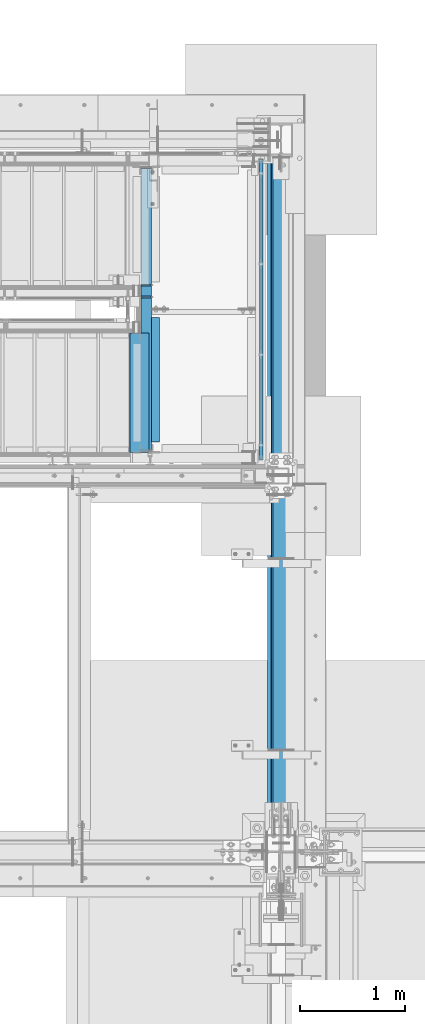
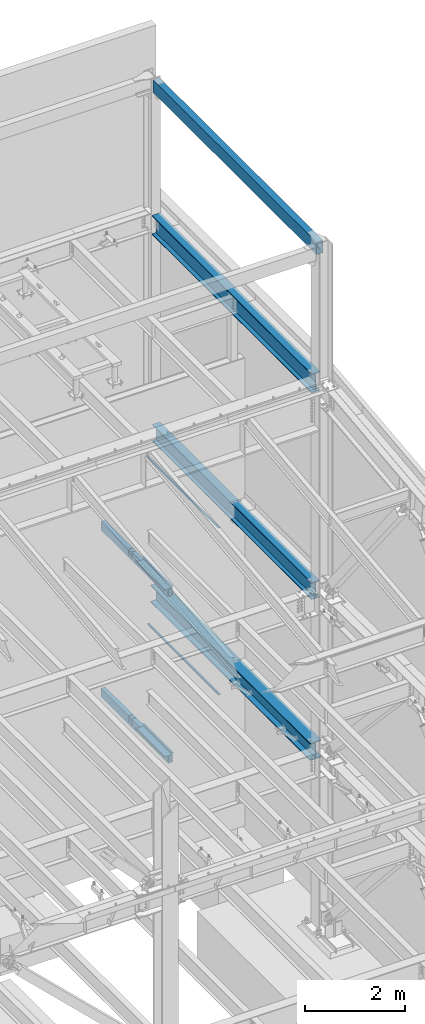
# One storey, part 787 of 1179: 10 beams, 2 members, 10 elements without a shape of their own.
"""IFC2X3 building model written with IfcOpenShell, lengths in millimetres."""

from ifc_helpers import new_model, si_unit, frame, origin_with_axes, place, context, subcontext, project, spatial, faceted_brep, material, type_object, element, aggregate, save


model = new_model("IFC2X3")

# Units and contexts
model_context = context("Model", 3, precision=1e-05, world=origin_with_axes())
body_context = subcontext(model_context, "Body", "Model", "MODEL_VIEW")
ifc_project = project(units=[si_unit("LENGTHUNIT", "METRE", prefix="MILLI"), si_unit("AREAUNIT", "SQUARE_METRE"), si_unit("VOLUMEUNIT", "CUBIC_METRE"), si_unit("MASSUNIT", "GRAM", prefix="KILO"), si_unit("TIMEUNIT", "SECOND"), si_unit("PLANEANGLEUNIT", "RADIAN"), si_unit("SOLIDANGLEUNIT", "STERADIAN"), si_unit("THERMODYNAMICTEMPERATUREUNIT", "DEGREE_CELSIUS"), si_unit("LUMINOUSINTENSITYUNIT", "LUMEN")], contexts=[model_context])

# Site, building, storey
site_placement = place(None, origin_with_axes())
site = spatial("IfcSite", under=ifc_project, at=site_placement, CompositionType="ELEMENT")
building_placement = place(site_placement, origin_with_axes())
building = spatial("IfcBuilding", under=site, at=building_placement, Name="Undefined", CompositionType="ELEMENT")
storey_placement = place(building_placement, origin_with_axes())
storey = spatial("IfcBuildingStorey", under=building, at=storey_placement, Name="Undefined", CompositionType="ELEMENT", Elevation=0.0)

# Assembly, member
assembly_1_placement = place(storey_placement, origin_with_axes())
assembly_1 = element("IfcElementAssembly", 1, at=assembly_1_placement, inside=storey, Name="GUARDRAIL", AssemblyPlace="NOTDEFINED", PredefinedType="RIGID_FRAME")
ifc_material_1 = material()
member_type = type_object("IfcMemberType", Name="HSS1-1/2X1-1/2X1/8", PredefinedType="NOTDEFINED")
member_1_placement = place(assembly_1_placement, frame((24114.1250004143, 38157.150000001, 7258.04999915355), z_axis=(0.0, 0.0, 1.0), x_axis=(0.0, 1.0, 0.0)))
member_1 = element("IfcMember", 2, at=member_1_placement, type_object=member_type, material=ifc_material_1, Name="GUARDRAIL", ObjectType="HSS1-1/2X1-1/2X1/8", context=body_context, shape_type="Brep", body=[
    faceted_brep([(15.874999282998, 15.874999282998, -15.8749992829999), (15.874999282998, -15.874999282998, -15.8749992829999), (2822.57500071677, -15.8749992830017, -15.8749992829999), (2822.57500071677, 15.8749992830017, -15.8749992829999), (-15.8749992830017, -15.874999282998, 15.8749992829999), (2854.32499928276, -15.8749992830017, 15.8749992829999), (-15.8749992830017, 15.874999282998, 15.8749992829999), (2854.32499928276, 15.8749992830017, 15.8749992829999), (19.0499999999993, 19.0499992349996, -19.0499992350015), (-19.0499992350015, 19.0499992350015, 19.0499992349996), (2857.49999923477, 19.0499992350015, 19.0499992349996), (2819.40000076476, 19.0499992350015, -19.0499992349996), (-19.0499992350015, -19.0499992350015, 19.0499992349996), (2857.49999923477, -19.0499992350015, 19.0499992349996), (19.0499999999993, -19.0499992349996, -19.0499992350015), (2819.40000076476, -19.0499992350015, -19.0499992349996)], [[[0, 1, 2, 3]], [[1, 4, 5, 2]], [[4, 6, 7, 5]], [[6, 0, 3, 7]], [[8, 9, 10, 11]], [[9, 12, 13, 10]], [[12, 14, 15, 13]], [[14, 8, 11, 15]], [[13, 15, 11, 10], [5, 7, 3, 2]], [[14, 12, 9, 8], [6, 4, 1, 0]]]),
])
aggregate(assembly_1, [member_1])

assembly_2_placement = place(storey_placement, origin_with_axes())
assembly_2 = element("IfcElementAssembly", 3, at=assembly_2_placement, inside=storey, Name="GUARDRAIL", AssemblyPlace="NOTDEFINED", PredefinedType="RIGID_FRAME")
member_2_placement = place(assembly_2_placement, frame((24114.1250004143, 38157.150000001, 3184.52499915355), z_axis=(0.0, 0.0, 1.0), x_axis=(0.0, 1.0, 0.0)))
member_2 = element("IfcMember", 4, at=member_2_placement, type_object=member_type, material=ifc_material_1, Name="GUARDRAIL", ObjectType="HSS1-1/2X1-1/2X1/8", context=body_context, shape_type="Brep", body=[
    faceted_brep([(15.874999282998, 15.874999282998, -15.8749992829999), (15.874999282998, -15.874999282998, -15.8749992829999), (2822.57500071677, -15.8749992830017, -15.8749992829999), (2822.57500071677, 15.8749992830017, -15.8749992829999), (-15.8749992830017, -15.874999282998, 15.8749992829999), (2854.32499928276, -15.8749992830017, 15.8749992829999), (-15.8749992830017, 15.874999282998, 15.8749992829999), (2854.32499928276, 15.8749992830017, 15.8749992829999), (19.0499999999993, 19.0499992349996, -19.0499992350015), (-19.0499992350015, 19.0499992350015, 19.0499992349996), (2857.49999923477, 19.0499992350015, 19.0499992349996), (2819.40000076476, 19.0499992350015, -19.0499992349996), (-19.0499992350015, -19.0499992350015, 19.0499992349996), (2857.49999923477, -19.0499992350015, 19.0499992349996), (19.0499999999993, -19.0499992349996, -19.0499992350015), (2819.40000076476, -19.0499992350015, -19.0499992349996)], [[[0, 1, 2, 3]], [[1, 4, 5, 2]], [[4, 6, 7, 5]], [[6, 0, 3, 7]], [[8, 9, 10, 11]], [[9, 12, 13, 10]], [[12, 14, 15, 13]], [[14, 8, 11, 15]], [[13, 15, 11, 10], [5, 7, 3, 2]], [[14, 12, 9, 8], [6, 4, 1, 0]]]),
])
aggregate(assembly_2, [member_2])

# Assembly, beam
assembly_3_placement = place(storey_placement, origin_with_axes())
assembly_3 = element("IfcElementAssembly", 5, at=assembly_3_placement, inside=storey, Name="BEAM", AssemblyPlace="NOTDEFINED", PredefinedType="RIGID_FRAME")
ifc_material_2 = material(Name="STEEL/A36")
beam_type_1 = type_object("IfcBeamType", Name="L3X3X1/4", PredefinedType="NOTDEFINED")
beam_1_placement = place(assembly_3_placement, frame((23107.6499999238, 38309.5499999837, 6051.55), z_axis=(1.0, 0.0, 0.0), x_axis=(0.0, 1.0, 0.0)))
beam_1 = element("IfcBeam", 6, at=beam_1_placement, type_object=beam_type_1, material=ifc_material_2, Name="ANGLE", ObjectType="L3X3X1/4", context=body_context, shape_type="Brep", body=[
    faceted_brep([(0.0, 38.0999999999985, -38.0999999999999), (0.0, 38.0999999999985, 38.0999999999999), (1191.0218750163, 38.1000000000004, 38.0999999999985), (1191.0218750163, 38.1000000000004, -38.0999999999985), (0.0, 31.75, 38.1000000000004), (1191.0218750163, 31.75, 38.0999999999985), (0.0, 31.75, -31.75), (1191.0218750163, 31.75, -31.75), (0.0, -38.0999999999985, -31.75), (1191.0218750163, -38.1000000000004, -31.75), (0.0, -38.0999999999985, -38.0999999999999), (1191.0218750163, -38.1000000000004, -38.0999999999985)], [[[0, 1, 2, 3]], [[1, 4, 5, 2]], [[4, 6, 7, 5]], [[6, 8, 9, 7]], [[8, 10, 11, 9]], [[10, 0, 3, 11]], [[5, 7, 9, 11, 3, 2]], [[10, 8, 6, 4, 1, 0]]]),
])

assembly_4_placement = place(storey_placement, origin_with_axes())
assembly_4 = element("IfcElementAssembly", 7, at=assembly_4_placement, inside=storey, Name="BEAM", AssemblyPlace="NOTDEFINED", PredefinedType="RIGID_FRAME")
beam_2_placement = place(assembly_4_placement, frame((23107.6500003381, 38309.5499999837, 1978.025), z_axis=(1.0, 0.0, 0.0), x_axis=(0.0, 1.0, 0.0)))
beam_2 = element("IfcBeam", 8, at=beam_2_placement, type_object=beam_type_1, material=ifc_material_2, Name="ANGLE", ObjectType="L3X3X1/4", context=body_context, shape_type="Brep", body=[
    faceted_brep([(0.0, 38.0999999999985, -38.0999999999999), (0.0, 38.0999999999985, 38.0999999999999), (1191.0218750163, 38.1000000000004, 38.0999999999985), (1191.0218750163, 38.1000000000004, -38.0999999999985), (0.0, 31.75, 38.1000000000004), (1191.0218750163, 31.75, 38.0999999999985), (0.0, 31.75, -31.75), (1191.0218750163, 31.75, -31.75), (0.0, -38.0999999999985, -31.75), (1191.0218750163, -38.1000000000004, -31.75), (0.0, -38.0999999999985, -38.0999999999999), (1191.0218750163, -38.1000000000004, -38.0999999999985)], [[[0, 1, 2, 3]], [[1, 4, 5, 2]], [[4, 6, 7, 5]], [[6, 8, 9, 7]], [[8, 10, 11, 9]], [[10, 0, 3, 11]], [[5, 7, 9, 11, 3, 2]], [[10, 8, 6, 4, 1, 0]]]),
])

assembly_5_placement = place(storey_placement, origin_with_axes())
assembly_5 = element("IfcElementAssembly", 9, at=assembly_5_placement, inside=storey, Name="STAIR", AssemblyPlace="NOTDEFINED", PredefinedType="RIGID_FRAME")
beam_type_2 = type_object("IfcBeamType", PredefinedType="NOTDEFINED")
beam_3_placement = place(assembly_5_placement, frame((23044.1500003691, 38779.4499999755, 6139.16000099702), z_axis=(0.0, -1.0, 0.0), x_axis=(-1.0, 0.0, 0.0)))
beam_3 = element("IfcBeam", 10, at=beam_3_placement, type_object=beam_type_2, material=ifc_material_2, Name="TREAD", context=body_context, shape_type="Brep", body=[
    faceted_brep([(0.0, -1.28999999999996, -571.5), (0.0, -1.28999999999996, 571.5), (0.0, 1.28999999999996, 571.5), (0.0, 1.28999999999996, -571.5), (180.270218519348, 1.28999999993903, 571.5), (180.270218519348, 1.28999999993903, -571.5), (178.030903291306, -1.29000000005999, -571.5), (178.030903291306, -1.29000000005999, 571.5), (185.938077784129, -38.5983376282238, 571.5), (185.938077784129, -38.5983376282238, -571.5), (183.38373559415, -38.9612921384341, 571.5), (183.38373559415, -38.9612921384341, -571.5)], [[[0, 1, 2, 3]], [[3, 2, 4, 5]], [[1, 0, 6, 7]], [[5, 4, 8, 9]], [[4, 2, 1, 7, 10, 8]], [[7, 6, 11, 10]], [[6, 0, 3, 5, 9, 11]], [[10, 11, 9, 8]]]),
])
aggregate(assembly_5, [beam_3])

assembly_6_placement = place(storey_placement, origin_with_axes())
assembly_6 = element("IfcElementAssembly", 11, at=assembly_6_placement, inside=storey, Name="STAIR", AssemblyPlace="NOTDEFINED", PredefinedType="RIGID_FRAME")
beam_4_placement = place(assembly_6_placement, frame((23044.1500003381, 38779.4499999749, 2065.635312), z_axis=(0.0, -1.0, 0.0), x_axis=(-1.0, 0.0, 0.0)))
beam_4 = element("IfcBeam", 12, at=beam_4_placement, type_object=beam_type_2, material=ifc_material_2, Name="TREAD", context=body_context, shape_type="Brep", body=[
    faceted_brep([(0.0, -1.28999999999996, -571.5), (0.0, -1.28999999999996, 571.5), (0.0, 1.28999999999996, 571.5), (0.0, 1.28999999999996, -571.5), (180.236168420404, 1.28999999999996, 571.5), (180.236168420404, 1.28999999999996, -571.5), (177.998572133125, -1.28999999999996, -571.5), (177.998572133125, -1.28999999999996, 571.5), (185.93476421485, -38.5969123680738, 571.5), (185.93476421485, -38.5969123680738, -571.5), (183.380698693989, -38.9618086754549, 571.5), (183.380698693989, -38.9618086754549, -571.5)], [[[0, 1, 2, 3]], [[3, 2, 4, 5]], [[1, 0, 6, 7]], [[5, 4, 8, 9]], [[4, 2, 1, 7, 10, 8]], [[7, 6, 11, 10]], [[6, 0, 3, 5, 9, 11]], [[10, 11, 9, 8]]]),
])
aggregate(assembly_6, [beam_4])

assembly_7_placement = place(storey_placement, origin_with_axes())
assembly_7 = element("IfcElementAssembly", 13, at=assembly_7_placement, inside=storey, Name="BEAM", AssemblyPlace="NOTDEFINED", PredefinedType="RIGID_FRAME")
beam_type_3 = type_object("IfcBeamType", Name="HSS12X6X3/8", PredefinedType="NOTDEFINED")
beam_5_placement = place(assembly_7_placement, frame((24307.8, 34469.3875, 16275.05), z_axis=(0.0, 0.0, 1.0), x_axis=(0.0, 1.0, 0.0)))
beam_5 = element("IfcBeam", 14, at=beam_5_placement, type_object=beam_type_3, material=ifc_material_1, Name="BEAM", ObjectType="HSS12X6X3/8", context=body_context, shape_type="Brep", body=[
    faceted_brep([(9.52500000000146, 66.675, -142.875), (9.52500000000146, -66.675, -142.875), (6556.37500000001, -66.6749999999993, -142.875), (6556.37500000001, 66.6749999999993, -142.875), (9.52500000000146, -66.675, 142.875000000002), (6556.37500000001, -66.6749999999993, 142.875000000002), (9.52500000000146, 66.675, 142.875000000002), (6556.37500000001, 66.6749999999993, 142.875000000002), (9.52500000000146, 76.2, -152.4), (9.52500000000146, 76.2, 152.4), (6556.37500000001, 76.2000000000007, 152.4), (6556.37500000001, 76.2000000000007, -152.4), (9.52500000000146, -76.2, 152.4), (6556.37500000001, -76.2000000000007, 152.4), (9.52500000000146, -76.2, -152.4), (6556.37500000001, -76.2000000000007, -152.4)], [[[0, 1, 2, 3]], [[1, 4, 5, 2]], [[4, 6, 7, 5]], [[6, 0, 3, 7]], [[8, 9, 10, 11]], [[9, 12, 13, 10]], [[12, 14, 15, 13]], [[14, 8, 11, 15]], [[13, 15, 11, 10], [5, 7, 3, 2]], [[14, 12, 9, 8], [6, 4, 1, 0]]]),
])
aggregate(assembly_7, [beam_5])

assembly_8_placement = place(storey_placement, origin_with_axes())
assembly_8 = element("IfcElementAssembly", 15, at=assembly_8_placement, inside=storey, Name="BEAM", AssemblyPlace="NOTDEFINED", PredefinedType="RIGID_FRAME")
ifc_material_3 = material(Name="STEEL/A992")
beam_type_4 = type_object("IfcBeamType", Name="W16X57", PredefinedType="NOTDEFINED")
beam_6_placement = place(assembly_8_placement, frame((24307.8, 34391.6, 7805.7375), z_axis=(0.0, 0.0, 1.0), x_axis=(0.0, 1.0, 0.0)))
beam_6 = element("IfcBeam", 16, at=beam_6_placement, type_object=beam_type_4, material=ifc_material_3, Name="BEAM", ObjectType="W16X57", context=body_context, shape_type="Brep", body=[
    faceted_brep([(249.237499999981, -90.4874999999993, -207.9625), (249.237499999981, 90.4874999999993, -207.9625), (6638.92500000001, 90.4874999999993, -207.9625), (6638.92500000001, -90.4874999999993, -207.9625), (249.237499999981, -90.4874999999993, -190.5), (249.237499999981, -5.55625000000146, -190.5), (249.237499999981, -5.55625000000146, -148.3775), (249.237499999981, -5.55625000000146, 157.9025), (249.237499999981, -5.55625000000146, 190.5), (249.237499999981, -90.4874999999993, 190.5), (249.237499999981, -90.4874999999993, 207.9625), (249.237499999981, 90.4874999999993, 207.9625), (249.237499999981, 90.4874999999993, 190.5), (249.237499999981, 5.55625000000146, 190.5), (249.237499999981, 5.55625000000146, -190.5), (249.237499999981, 90.4874999999993, -190.5), (6638.92500000001, -90.4874999999993, -190.5), (6638.92500000001, -5.55625000000146, -190.5), (6638.92500000001, -5.55625000000146, 190.5), (6638.92500000001, -90.4874999999993, 190.5), (6638.92500000001, -90.4874999999993, 207.9625), (6638.92500000001, 90.4874999999993, 207.9625), (6638.92500000001, 90.4874999999993, 190.5), (6638.92500000001, 5.55625000000146, 190.5), (6638.92500000001, 5.55625000000146, -190.5), (6638.92500000001, 90.4874999999993, -190.5)], [[[0, 1, 2, 3]], [[0, 4, 5, 6, 7, 8, 9, 10, 11, 12, 13, 14, 15, 1]], [[5, 4, 16, 17]], [[8, 7, 6, 5, 17, 18]], [[9, 8, 18, 19]], [[10, 9, 19, 20]], [[11, 10, 20, 21]], [[12, 11, 21, 22]], [[13, 12, 22, 23]], [[14, 13, 23, 24]], [[15, 14, 24, 25]], [[1, 15, 25, 2]], [[24, 23, 22, 21, 20, 19, 18, 17, 16, 3, 2, 25]], [[4, 0, 3, 16]]]),
])
aggregate(assembly_8, [beam_6])

assembly_9_placement = place(storey_placement, origin_with_axes())
assembly_9 = element("IfcElementAssembly", 17, at=assembly_9_placement, inside=storey, Name="BEAM", AssemblyPlace="NOTDEFINED", PredefinedType="RIGID_FRAME")
beam_type_5 = type_object("IfcBeamType", Name="W18X65", PredefinedType="NOTDEFINED")
beam_7_placement = place(assembly_9_placement, frame((24307.8, 34391.6, 12885.7375), z_axis=(0.0, 0.0, 1.0), x_axis=(0.0, 1.0, 0.0)))
beam_7 = element("IfcBeam", 18, at=beam_7_placement, type_object=beam_type_5, material=ifc_material_3, Name="BEAM", ObjectType="W18X65", context=body_context, shape_type="Brep", body=[
    faceted_brep([(247.650000000016, -96.8375000000015, -233.362499999999), (247.650000000016, 96.8375000000015, -233.362499999999), (6638.92500000001, 96.8375000000015, -233.362499999999), (6638.92500000001, -96.8375000000015, -233.362499999999), (247.650000000016, -96.8375000000015, -214.3125), (247.650000000016, -5.55625000000146, -214.3125), (247.650000000016, -5.55625000000146, 214.3125), (247.650000000016, -96.8375000000015, 214.3125), (247.650000000016, -96.8375000000015, 233.362499999999), (247.650000000016, 96.8375000000015, 233.362499999999), (247.650000000016, 96.8375000000015, 214.3125), (247.650000000016, 5.55625000000146, 214.3125), (247.650000000001, 5.55625000000146, 183.302500000156), (247.650000000001, 5.55625000000146, -122.97749999995), (247.650000000016, 5.55625000000146, -214.3125), (247.650000000016, 96.8375000000015, -214.3125), (6638.92500000001, -96.8375000000015, -214.3125), (6638.92500000001, -5.55625000000146, -214.3125), (6638.92500000001, -5.55625000000146, 214.3125), (6638.92500000001, -96.8375000000015, 214.3125), (6638.92500000001, -96.8375000000015, 233.362499999999), (6638.92500000001, 96.8375000000015, 233.362499999999), (6638.92500000001, 96.8375000000015, 214.3125), (6638.92500000001, 5.55625000000146, 214.3125), (6638.92500000001, 5.55625000000146, -214.3125), (6638.92500000001, 96.8375000000015, -214.3125)], [[[0, 1, 2, 3]], [[0, 4, 5, 6, 7, 8, 9, 10, 11, 12, 13, 14, 15, 1]], [[5, 4, 16, 17]], [[6, 5, 17, 18]], [[7, 6, 18, 19]], [[8, 7, 19, 20]], [[9, 8, 20, 21]], [[10, 9, 21, 22]], [[11, 10, 22, 23]], [[14, 13, 12, 11, 23, 24]], [[15, 14, 24, 25]], [[1, 15, 25, 2]], [[24, 23, 22, 21, 20, 19, 18, 17, 16, 3, 2, 25]], [[4, 0, 3, 16]]]),
])
aggregate(assembly_9, [beam_7])

# Beam
beam_type_6 = type_object("IfcBeamType", Name="HSS8X4X3/8", PredefinedType="NOTDEFINED")
beam_8_placement = place(assembly_3_placement, frame((23018.7499999835, 38201.5999999962, 6036.27000099707), z_axis=(0.0, 0.0, 1.0), x_axis=(0.0, 1.0, 0.0)))
beam_8 = element("IfcBeam", 19, at=beam_8_placement, type_object=beam_type_6, material=ifc_material_1, Name="BEAM", ObjectType="HSS8X4X3/8", context=body_context, shape_type="Brep", body=[
    faceted_brep([(1614.48750004428, -50.7999999999993, -63.4999999999991), (1614.48750004428, -41.2750000000015, -63.4999999999991), (1598.61250004428, -41.2750000000015, -63.4999999999991), (1598.61250004428, -50.7999999999993, -63.4999999999991), (1598.61250004428, -50.7999999999993, 101.599999999564), (1598.61250004428, -41.2750000000015, 92.0749999999998), (1598.61250004428, 41.2750000000015, 92.0749999999998), (1598.61250004428, 41.2750000000015, -63.4999999999991), (1598.61250004428, 50.7999999999993, -63.4999999999991), (1598.61250004428, 50.7999999999993, 101.6), (1614.48750004428, 41.2750000000015, -63.4999999999991), (1614.48750004428, 50.7999999999993, -63.4999999999991), (1614.48750012656, -50.7999999999993, 101.6), (1614.48750012656, 50.7999999999993, 101.6), (1614.48750012182, 41.2750000000015, 92.0749999999998), (1614.48750012182, -41.2750000000015, 92.0749999999998), (1500.18750004428, 50.7999999999993, 101.6), (1500.18750004428, -50.7999999999993, 101.599999999526), (1500.187499962, 41.2750000000015, -63.5000000004738), (1500.187499962, 50.7999999999993, -63.5000000004738), (1484.312499962, 50.7999999999993, -63.5000000004738), (1484.312499962, 41.2750000000015, -63.5000000004738), (1500.18750003954, 41.2750000000015, 92.0749999999998), (1500.18750003954, -41.2750000000015, 92.0749999999998), (1500.187499962, -41.2750000000015, -63.5000000004738), (1500.187499962, -50.7999999999993, -63.5000000004738), (1484.312499962, -41.2750000000015, -63.5000000004738), (1484.312499962, -50.7999999999993, -63.5000000004738), (28.574999979166, 50.7999999999993, 101.6), (28.574999979166, -50.7999999999993, 101.6), (1484.312499962, -50.7999999999993, 101.6), (1484.312499962, 50.7999999999993, 101.6), (28.574999979166, -50.7999999999993, -101.6), (28.574999979166, 50.7999999999993, -101.6), (2720.97500000427, 50.7999999999993, -101.6), (2720.97500000427, -50.7999999999993, -101.6), (2720.97500000427, -50.7999999999993, 101.6), (2720.97500000427, 50.7999999999993, 101.6), (1484.312499962, -41.2750000000015, 92.0749999999998), (1484.312499962, 41.2750000000015, 92.0749999999998), (28.574999979166, -41.2750000000015, 92.0749999999998), (28.574999979166, 41.2750000000015, 92.0749999999998), (28.574999979166, -41.2750000000015, -92.0749999999998), (28.574999979166, 41.2750000000015, -92.0749999999998), (2720.97500000427, -41.2750000000015, -92.0749999999998), (2720.97500000427, 41.2750000000015, -92.0749999999998), (2720.97500000427, -41.2750000000015, 92.0749999999998), (2720.97500000427, 41.2750000000015, 92.0749999999998)], [[[0, 1, 2, 3]], [[4, 3, 2, 5, 6, 7, 8, 9]], [[10, 11, 8, 7]], [[12, 13, 11, 10, 14, 15, 1, 0]], [[16, 17, 4, 9]], [[18, 19, 20, 21]], [[17, 16, 19, 18, 22, 23, 24, 25]], [[25, 24, 26, 27]], [[28, 29, 30, 31]], [[32, 33, 34, 35]], [[3, 4, 17, 25, 27, 30, 29, 32, 35, 36, 12, 0]], [[36, 37, 13, 12]], [[37, 34, 33, 28, 31, 20, 19, 16, 9, 8, 11, 13]], [[30, 27, 26, 38, 39, 21, 20, 31]], [[40, 41, 39, 38]], [[32, 29, 28, 33], [41, 40, 42, 43]], [[43, 42, 44, 45]], [[36, 35, 34, 37], [46, 47, 45, 44]], [[47, 46, 15, 14]], [[7, 6, 22, 18, 21, 39, 41, 43, 45, 47, 14, 10]], [[23, 22, 6, 5]], [[46, 44, 42, 40, 38, 26, 24, 23, 5, 2, 1, 15]]]),
])

aggregate(assembly_3, [beam_1, beam_8])

beam_9_placement = place(assembly_4_placement, frame((23018.7500003381, 38207.95, 1962.745312), z_axis=(0.0, 0.0, 1.0), x_axis=(0.0, 1.0, 0.0)))
beam_9 = element("IfcBeam", 20, at=beam_9_placement, type_object=beam_type_6, material=ifc_material_1, Name="BEAM", ObjectType="HSS8X4X3/8", context=body_context, shape_type="Brep", body=[
    faceted_brep([(1608.13750004221, -50.7999999999993, -63.5000000000173), (1608.13750004221, -41.2750000000015, -63.5000000000173), (1592.26250003877, -41.2750000000015, -63.4999999999823), (1592.26250003877, -50.7999999999993, -63.4999999999823), (1592.26250002901, -50.7999999999993, 101.600000005448), (1592.26250002957, -41.2750000000015, 92.0749999999998), (1592.26250002957, 41.2750000000015, 92.0749999999998), (1592.26250003877, 41.2750000000015, -63.4999999999823), (1592.26250003877, 50.7999999999993, -63.4999999999823), (1592.26250002901, 50.7999999999993, 101.6), (1608.13750004221, 41.2750000000015, -63.5000000000173), (1608.13750004221, 50.7999999999993, -63.5000000000173), (1608.13750011009, -50.7999999999993, 101.600000006383), (1608.13750011009, 50.7999999999993, 101.6), (1608.13750010618, 41.2750000000015, 92.0749999999998), (1608.13750010618, -41.2750000000015, 92.0749999999998), (1493.83750002953, 50.7999999999993, 101.6), (1493.83750002953, -50.7999999999993, 101.600000005926), (1493.83749996165, 41.2750000000015, -63.5000000004741), (1493.83749996165, 50.7999999999993, -63.5000000004741), (1477.96249995821, 50.7999999999993, -63.5000000004391), (1477.96249995821, 41.2750000000015, -63.5000000004391), (1493.83750002561, 41.2750000000015, 92.0749999999998), (1493.83750002561, -41.2750000000015, 92.0749999999998), (1493.83749996165, -41.2750000000015, -63.5000000004741), (1493.83749996165, -50.7999999999993, -63.5000000004741), (1477.96249995821, -41.2750000000015, -63.5000000004391), (1477.96249995821, -50.7999999999993, -63.5000000004391), (22.2249999747728, 50.7999999999993, 101.6), (22.2249999747728, -50.7999999999993, 101.6), (1477.96249994844, -50.7999999999993, 101.6), (1477.96249994844, 50.7999999999993, 101.6), (22.2249999747728, -50.7999999999993, -101.6), (22.2249999747728, 50.7999999999993, -101.6), (2714.62499999975, 50.7999999999993, -101.6), (2714.62499999975, -50.7999999999993, -101.6), (2714.62499999975, -50.7999999999993, 101.6), (2714.62499999975, 50.7999999999993, 101.6), (1477.962499949, -41.2750000000015, 92.0749999999998), (1477.962499949, 41.2750000000015, 92.0749999999998), (22.2249999747728, -41.2750000000015, 92.0749999999998), (22.2249999747728, 41.2750000000015, 92.0749999999998), (22.2249999747728, -41.2750000000015, -92.075), (22.2249999747728, 41.2750000000015, -92.075), (2714.62499999975, -41.2750000000015, -92.075), (2714.62499999975, 41.2750000000015, -92.075), (2714.62499999975, -41.2750000000015, 92.0749999999998), (2714.62499999975, 41.2750000000015, 92.0749999999998)], [[[0, 1, 2, 3]], [[4, 3, 2, 5, 6, 7, 8, 9]], [[10, 11, 8, 7]], [[12, 13, 11, 10, 14, 15, 1, 0]], [[16, 17, 4, 9]], [[18, 19, 20, 21]], [[17, 16, 19, 18, 22, 23, 24, 25]], [[25, 24, 26, 27]], [[28, 29, 30, 31]], [[32, 33, 34, 35]], [[3, 4, 17, 25, 27, 30, 29, 32, 35, 36, 12, 0]], [[36, 37, 13, 12]], [[37, 34, 33, 28, 31, 20, 19, 16, 9, 8, 11, 13]], [[30, 27, 26, 38, 39, 21, 20, 31]], [[40, 41, 39, 38]], [[32, 29, 28, 33], [41, 40, 42, 43]], [[43, 42, 44, 45]], [[36, 35, 34, 37], [46, 47, 45, 44]], [[47, 46, 15, 14]], [[7, 6, 22, 18, 21, 39, 41, 43, 45, 47, 14, 10]], [[23, 22, 6, 5]], [[46, 44, 42, 40, 38, 26, 24, 23, 5, 2, 1, 15]]]),
])

aggregate(assembly_4, [beam_2, beam_9])

# Assembly, beam
assembly_10_placement = place(storey_placement, origin_with_axes())
assembly_10 = element("IfcElementAssembly", 21, at=assembly_10_placement, inside=storey, Name="BEAM", AssemblyPlace="NOTDEFINED", PredefinedType="RIGID_FRAME")
beam_type_7 = type_object("IfcBeamType", Name="W16X77", PredefinedType="NOTDEFINED")
beam_10_placement = place(assembly_10_placement, frame((24307.8, 34391.6, 3892.55), z_axis=(0.0, 0.0, 1.0), x_axis=(0.0, 1.0, 0.0)))
beam_10 = element("IfcBeam", 22, at=beam_10_placement, type_object=beam_type_7, material=ifc_material_3, Name="BEAM", ObjectType="W16X77", context=body_context, shape_type="Brep", body=[
    faceted_brep([(247.650000000001, -130.174999999999, -209.55), (247.650000000001, 130.174999999999, -209.55), (6638.92500000001, 130.174999999999, -209.55), (6638.92500000001, -130.174999999999, -209.55), (247.650000000001, -130.174999999999, -190.5), (247.649999999994, -5.55624999999998, -190.5), (247.649999999994, -5.55624999999998, 190.5), (247.650000000001, -130.174999999999, 190.5), (247.650000000001, -130.174999999999, 209.55), (247.650000000001, 130.174999999999, 209.55), (247.650000000001, 130.174999999999, 190.5), (247.649999999994, 5.55624999999998, 190.5), (247.650000000001, 5.55625000000146, 159.490000000109), (247.650000000001, 5.55625000000146, -146.789999999992), (247.649999999994, 5.55624999999998, -190.5), (247.650000000001, 130.174999999999, -190.5), (6638.92500000001, -130.174999999999, -190.5), (6638.92500000001, -5.55625000000146, -190.5), (6638.92500000001, -5.55625000000146, 190.5), (6638.92500000001, -130.174999999999, 190.5), (6638.92500000001, -130.174999999999, 209.55), (6638.92500000001, 130.174999999999, 209.55), (6638.92500000001, 130.174999999999, 190.5), (6638.92500000001, 5.55625000000146, 190.5), (6638.92500000001, 5.55625000000146, -190.5), (6638.92500000001, 130.174999999999, -190.5)], [[[0, 1, 2, 3]], [[0, 4, 5, 6, 7, 8, 9, 10, 11, 12, 13, 14, 15, 1]], [[5, 4, 16, 17]], [[6, 5, 17, 18]], [[7, 6, 18, 19]], [[8, 7, 19, 20]], [[9, 8, 20, 21]], [[10, 9, 21, 22]], [[11, 10, 22, 23]], [[14, 13, 12, 11, 23, 24]], [[15, 14, 24, 25]], [[1, 15, 25, 2]], [[24, 23, 22, 21, 20, 19, 18, 17, 16, 3, 2, 25]], [[4, 0, 3, 16]]]),
])
aggregate(assembly_10, [beam_10])

save(model, "model.ifc")
